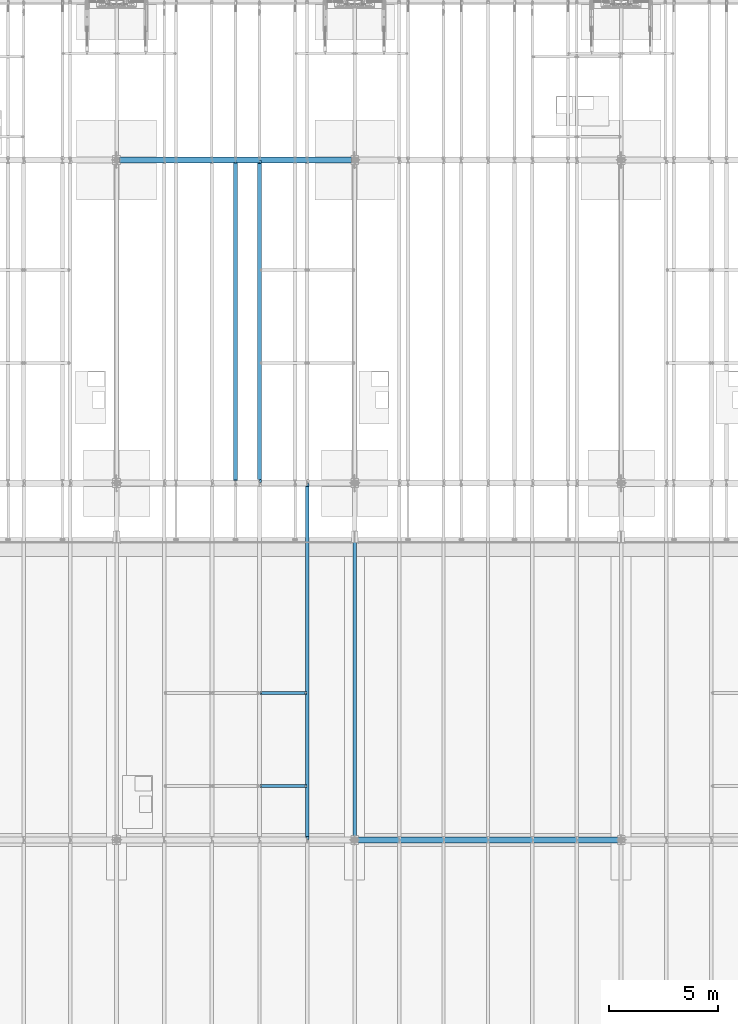
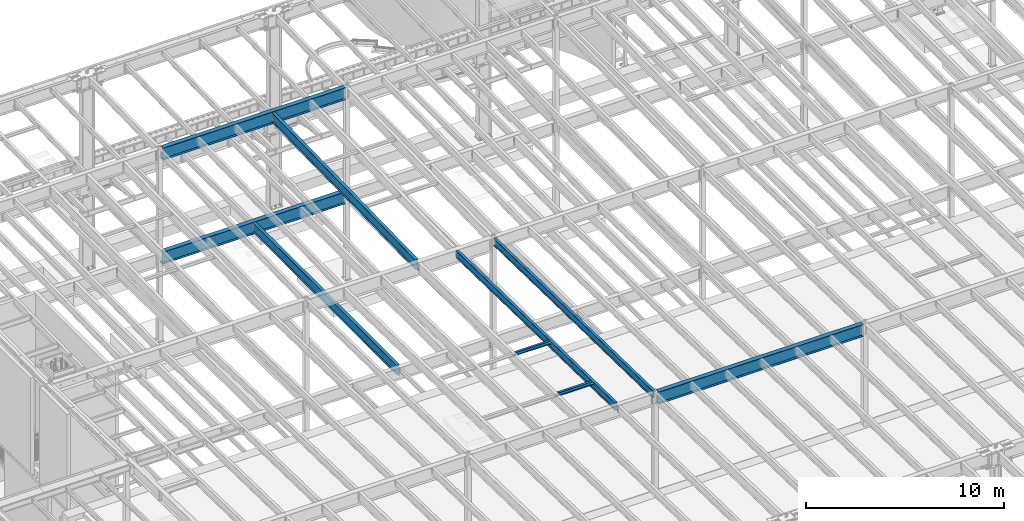
# One storey, part 1099 of 1763: 9 beams, 9 elements without a shape of their own.
"""IFC2X3 building model written with IfcOpenShell, lengths in millimetres."""

from ifc_helpers import new_model, si_unit, frame, origin_with_axes, place, context, subcontext, project, spatial, faceted_brep, material, type_object, element, aggregate, save


model = new_model("IFC2X3")

# Units and contexts
model_context = context("Model", 3, precision=1e-05, world=origin_with_axes())
body_context = subcontext(model_context, "Body", "Model", "MODEL_VIEW")
ifc_project = project(units=[si_unit("LENGTHUNIT", "METRE", prefix="MILLI"), si_unit("AREAUNIT", "SQUARE_METRE"), si_unit("VOLUMEUNIT", "CUBIC_METRE"), si_unit("MASSUNIT", "GRAM", prefix="KILO"), si_unit("TIMEUNIT", "SECOND"), si_unit("PLANEANGLEUNIT", "RADIAN"), si_unit("SOLIDANGLEUNIT", "STERADIAN"), si_unit("THERMODYNAMICTEMPERATUREUNIT", "DEGREE_CELSIUS"), si_unit("LUMINOUSINTENSITYUNIT", "LUMEN")], contexts=[model_context])

# Site, building, storey
site_placement = place(None, origin_with_axes())
site = spatial("IfcSite", under=ifc_project, at=site_placement, CompositionType="ELEMENT")
building_placement = place(site_placement, origin_with_axes())
building = spatial("IfcBuilding", under=site, at=building_placement, Name="Undefined", CompositionType="ELEMENT")
storey_placement = place(building_placement, origin_with_axes())
storey = spatial("IfcBuildingStorey", under=building, at=storey_placement, Name="Undefined", CompositionType="ELEMENT", Elevation=0.0)

# Assembly, beam
assembly_1_placement = place(storey_placement, origin_with_axes())
assembly_1 = element("IfcElementAssembly", 1, at=assembly_1_placement, inside=storey, Name="BEAM", AssemblyPlace="NOTDEFINED", PredefinedType="RIGID_FRAME")
ifc_material = material(Name="STEEL/A992")
beam_type_1 = type_object("IfcBeamType", Name="W8X18", PredefinedType="NOTDEFINED")
beam_1_placement = place(assembly_1_placement, frame((-65953.0772736984, 20421.6, 11387.8344547136), z_axis=(0.0, 0.0, 1.0), x_axis=(1.0, 0.0, 0.0)))
beam_1 = element("IfcBeam", 2, at=beam_1_placement, type_object=beam_type_1, material=ifc_material, Name="BEAM", ObjectType="W8X18", context=body_context, shape_type="Brep", body=[
    faceted_brep([(2086.45125000002, -66.6749999999993, 103.1875), (2086.45125000002, -66.6749999999993, 95.25), (2086.45125000002, -3.17499999999927, 95.25), (2086.45125000002, -3.17499999999927, 83.8775014899638), (2086.45125000002, 3.17499999999927, 83.8775014899638), (2086.45125000002, 3.17499999999927, 95.25), (2086.45125000002, 66.6749999999993, 95.25), (2086.45125000002, 66.6749999999993, 103.1875), (2087.41797992261, -3.17499999999927, 79.0174219719174), (2087.41797992261, 3.17499999999927, 79.0174219719174), (2090.17099382309, -3.17499999999927, 74.8972455037638), (2090.17099382309, 3.17499999999927, 74.8972455037638), (2094.29117029124, -3.17499999999927, 72.1442316032862), (2094.29117029124, 3.17499999999927, 72.1442316032862), (2099.15124980929, -3.17499999999927, 71.1775016806987), (2099.15124980929, 3.17499999999927, 71.1775016806987), (2162.65125000002, -3.17499999999927, 71.1775016806987), (2162.65125000002, 3.17499999999927, 71.1775016806987), (101.599996948244, -66.6750000000002, 103.1875), (101.599996948244, 66.6750000000002, 103.1875), (101.599996948244, 66.6750000000002, 95.25), (101.599996948244, 3.17500000000018, 95.25), (101.599996948244, 3.17500000000018, 79.3006453379949), (101.599996948244, -3.17500000000018, 79.3006453379949), (101.599996948244, -3.17500000000018, 95.25), (101.599996948244, -66.6750000000002, 95.25), (100.633267025656, 3.17500000000018, 74.4405658199485), (100.633267025656, -3.17500000000018, 74.4405658199485), (97.8802531251786, 3.17500000000018, 70.3203893517948), (97.8802531251786, -3.17500000000018, 70.3203893517948), (97.1527139098253, 3.17500000000018, 69.8342631898486), (97.1527139098253, -3.17500000000018, 69.8342631898486), (96.2927561769247, 3.17500000000018, 68.5472454911378), (96.2927561769247, -3.17500000000018, 68.5472454911378), (92.1725797087711, 3.17500000000018, 65.7942315906603), (92.1725797087711, -3.17500000000018, 65.7942315906603), (87.3125001907247, 3.17500000000018, 64.8275016680727), (87.3125001907247, -3.17500000000018, 64.8275016680727), (17.4624999999905, 3.17500000000018, 64.8275016680727), (17.4624999999905, -3.17500000000018, 64.8275016680727), (17.4624999999905, 3.17500000000018, -95.25), (17.4624999999905, 66.6750000000002, -95.25), (17.4624999999905, 66.6750000000002, -103.1875), (17.4624999999905, -66.6750000000002, -103.1875), (17.4624999999905, -66.6750000000002, -95.25), (17.4624999999905, -3.17500000000018, -95.25), (2162.65125000002, 3.17499999999927, -95.25), (2162.65125000002, 66.6749999999993, -95.25), (2162.65125000002, 66.6749999999993, -103.1875), (2162.65125000002, -66.6749999999993, -103.1875), (2162.65125000002, -66.6749999999993, -95.25), (2162.65125000002, -3.17499999999927, -95.25)], [[[0, 1, 2, 3, 4, 5, 6, 7]], [[8, 9, 4, 3]], [[10, 11, 9, 8]], [[12, 13, 11, 10]], [[14, 15, 13, 12]], [[16, 17, 15, 14]], [[18, 19, 20, 21, 22, 23, 24, 25]], [[23, 22, 26, 27]], [[27, 26, 28, 29]], [[29, 28, 30, 31]], [[31, 30, 32, 33]], [[33, 32, 34, 35]], [[35, 34, 36, 37]], [[37, 36, 38, 39]], [[40, 41, 42, 43, 44, 45, 39, 38]], [[41, 40, 46, 47]], [[42, 41, 47, 48]], [[43, 42, 48, 49]], [[44, 43, 49, 50]], [[45, 44, 50, 51]], [[12, 10, 8, 3, 2, 24, 23, 27, 29, 31, 33, 35, 37, 39, 45, 51, 16, 14]], [[25, 24, 2, 1]], [[18, 25, 1, 0]], [[19, 18, 0, 7]], [[20, 19, 7, 6]], [[21, 20, 6, 5]], [[46, 40, 38, 36, 34, 32, 30, 28, 26, 22, 21, 5, 4, 9, 11, 13, 15, 17]], [[51, 50, 49, 48, 47, 46, 17, 16]]]),
])
aggregate(assembly_1, [beam_1])

assembly_2_placement = place(storey_placement, origin_with_axes())
assembly_2 = element("IfcElementAssembly", 3, at=assembly_2_placement, inside=storey, Name="BEAM", AssemblyPlace="NOTDEFINED", PredefinedType="RIGID_FRAME")
beam_2_placement = place(assembly_2_placement, frame((-65953.0772736984, 16154.4, 11477.0442138004), z_axis=(0.0, 0.0, 1.0), x_axis=(1.0, 0.0, 0.0)))
beam_2 = element("IfcBeam", 4, at=beam_2_placement, type_object=beam_type_1, material=ifc_material, Name="BEAM", ObjectType="W8X18", context=body_context, shape_type="Brep", body=[
    faceted_brep([(2086.45125000002, -66.6749999999993, 103.1875), (2086.45125000002, -66.6749999999993, 95.25), (2086.45125000002, -3.17499999999927, 95.25), (2086.45125000002, -3.17499999999927, 83.8775014899638), (2086.45125000002, 3.17499999999927, 83.8775014899638), (2086.45125000002, 3.17499999999927, 95.25), (2086.45125000002, 66.6749999999993, 95.25), (2086.45125000002, 66.6749999999993, 103.1875), (2087.41797992261, -3.17499999999927, 79.0174219719174), (2087.41797992261, 3.17499999999927, 79.0174219719174), (2090.17099382309, -3.17499999999927, 74.8972455037638), (2090.17099382309, 3.17499999999927, 74.8972455037638), (2094.29117029124, -3.17499999999927, 72.1442316032862), (2094.29117029124, 3.17499999999927, 72.1442316032862), (2099.15124980929, -3.17499999999927, 71.1775016806987), (2099.15124980929, 3.17499999999927, 71.1775016806987), (2162.65125000002, -3.17499999999927, 71.1775016806987), (2162.65125000002, 3.17499999999927, 71.1775016806987), (101.599996948244, -66.6750000000002, 103.1875), (101.599996948244, 66.6750000000002, 103.1875), (101.599996948244, 66.6750000000002, 95.25), (101.599996948244, 3.17500000000018, 95.25), (101.599996948244, 3.17500000000018, 79.3006453379949), (101.599996948244, -3.17500000000018, 79.3006453379949), (101.599996948244, -3.17500000000018, 95.25), (101.599996948244, -66.6750000000002, 95.25), (100.633267025656, 3.17500000000018, 74.4405658199485), (100.633267025656, -3.17500000000018, 74.4405658199485), (97.8802531251786, 3.17500000000018, 70.3203893517948), (97.8802531251786, -3.17500000000018, 70.3203893517948), (97.1527139098253, 3.17500000000018, 69.8342631898486), (97.1527139098253, -3.17500000000018, 69.8342631898486), (96.2927561769247, 3.17500000000018, 68.5472454911378), (96.2927561769247, -3.17500000000018, 68.5472454911378), (92.1725797087711, 3.17500000000018, 65.7942315906603), (92.1725797087711, -3.17500000000018, 65.7942315906603), (87.3125001907247, 3.17500000000018, 64.8275016680727), (87.3125001907247, -3.17500000000018, 64.8275016680727), (17.4624999999905, 3.17500000000018, 64.8275016680727), (17.4624999999905, -3.17500000000018, 64.8275016680727), (17.4624999999905, 3.17500000000018, -95.25), (17.4624999999905, 66.6750000000002, -95.25), (17.4624999999905, 66.6750000000002, -103.1875), (17.4624999999905, -66.6750000000002, -103.1875), (17.4624999999905, -66.6750000000002, -95.25), (17.4624999999905, -3.17500000000018, -95.25), (2162.65125000002, 3.17499999999927, -95.25), (2162.65125000002, 66.6749999999993, -95.25), (2162.65125000002, 66.6749999999993, -103.1875), (2162.65125000002, -66.6749999999993, -103.1875), (2162.65125000002, -66.6749999999993, -95.25), (2162.65125000002, -3.17499999999927, -95.25)], [[[0, 1, 2, 3, 4, 5, 6, 7]], [[8, 9, 4, 3]], [[10, 11, 9, 8]], [[12, 13, 11, 10]], [[14, 15, 13, 12]], [[16, 17, 15, 14]], [[18, 19, 20, 21, 22, 23, 24, 25]], [[23, 22, 26, 27]], [[27, 26, 28, 29]], [[29, 28, 30, 31]], [[31, 30, 32, 33]], [[33, 32, 34, 35]], [[35, 34, 36, 37]], [[37, 36, 38, 39]], [[40, 41, 42, 43, 44, 45, 39, 38]], [[41, 40, 46, 47]], [[42, 41, 47, 48]], [[43, 42, 48, 49]], [[44, 43, 49, 50]], [[45, 44, 50, 51]], [[12, 10, 8, 3, 2, 24, 23, 27, 29, 31, 33, 35, 37, 39, 45, 51, 16, 14]], [[25, 24, 2, 1]], [[18, 25, 1, 0]], [[19, 18, 0, 7]], [[20, 19, 7, 6]], [[21, 20, 6, 5]], [[46, 40, 38, 36, 34, 32, 30, 28, 26, 22, 21, 5, 4, 9, 11, 13, 15, 17]], [[51, 50, 49, 48, 47, 46, 17, 16]]]),
])
aggregate(assembly_2, [beam_2])

assembly_3_placement = place(storey_placement, origin_with_axes())
assembly_3 = element("IfcElementAssembly", 5, at=assembly_3_placement, inside=storey, Name="BEAM", AssemblyPlace="NOTDEFINED", PredefinedType="RIGID_FRAME")
beam_type_2 = type_object("IfcBeamType", Name="W18X40", PredefinedType="NOTDEFINED")
beam_3_placement = place(assembly_3_placement, frame((-61594.4372736983, 13685.8551306911, 11404.7768219844), z_axis=(0.0, 0.0209013539966291, 0.999781542838788), x_axis=(0.0, 0.999781542776098, -0.0209013569953182)))
beam_3 = element("IfcBeam", 6, at=beam_3_placement, type_object=beam_type_2, material=ifc_material, Name="BEAM", ObjectType="W18X40", context=body_context, shape_type="Brep", body=[
    faceted_brep([(149.222337311263, -76.1999999999971, -227.012499999879), (149.222337311263, 76.1999999999971, -227.012499999879), (16200.7664130645, 76.1999999999971, -227.012499990429), (16200.7664130645, -76.1999999999971, -227.012499990429), (148.956832075886, -76.1999999999971, -214.31249999988), (148.956832075886, -3.96875, -214.31249999988), (139.996051629378, -3.96875, 214.31249999976), (139.996051629378, -76.1999999999971, 214.31249999976), (139.730529250521, -76.1999999999971, 227.012499999752), (139.730529250521, 76.1999999999971, 227.012499999752), (139.996051629378, 76.1999999999971, 214.31249999976), (139.996051629378, 3.96875, 214.31249999976), (148.956832075886, 3.96875, -214.31249999988), (148.956832075886, 76.1999999999971, -214.31249999988), (16200.5009078292, -76.1999999999971, -214.31249999043), (16200.5009078292, -3.96875, -214.31249999043), (16191.5401061352, -3.96875, 214.312500009502), (16191.5401061352, -76.1999999999971, 214.312500009502), (16191.2746008998, -76.1999999999971, 227.012500009499), (16191.2746008998, 76.1999999999971, 227.012500009499), (16191.5401061352, 76.1999999999971, 214.312500009502), (16191.5401061352, 3.96875, 214.312500009502), (16200.5009078292, 3.96875, -214.31249999043), (16200.5009078292, 76.1999999999971, -214.31249999043)], [[[0, 1, 2, 3]], [[0, 4, 5, 6, 7, 8, 9, 10, 11, 12, 13, 1]], [[5, 4, 14, 15]], [[6, 5, 15, 16]], [[7, 6, 16, 17]], [[8, 7, 17, 18]], [[9, 8, 18, 19]], [[10, 9, 19, 20]], [[11, 10, 20, 21]], [[12, 11, 21, 22]], [[13, 12, 22, 23]], [[1, 13, 23, 2]], [[22, 21, 20, 19, 18, 17, 16, 15, 14, 3, 2, 23]], [[4, 0, 3, 14]]]),
])
aggregate(assembly_3, [beam_3])

assembly_4_placement = place(storey_placement, origin_with_axes())
assembly_4 = element("IfcElementAssembly", 7, at=assembly_4_placement, inside=storey, Name="BEAM", AssemblyPlace="NOTDEFINED", PredefinedType="RIGID_FRAME")
beam_4_placement = place(assembly_4_placement, frame((-63773.7572736983, 13685.8551306872, 11404.7768219843), z_axis=(0.0, 0.0209013539966291, 0.999781542838788), x_axis=(0.0, 0.999781542776098, -0.0209013569953182)))
beam_4 = element("IfcBeam", 8, at=beam_4_placement, type_object=beam_type_2, material=ifc_material, Name="BEAM", ObjectType="W18X40", context=body_context, shape_type="Brep", body=[
    faceted_brep([(131.750078376836, 4.26866853544198, -214.312499999891), (131.750078376825, 4.26882839153404, -227.012499999888), (28.545974688046, 4.26881528460945, -227.012499999948), (28.2804694526694, 4.26865539480787, -214.312499999951), (131.750069241622, 76.1999999999971, -214.312499999891), (131.750069241631, 76.1999999999971, -227.012499999888), (150.800068605527, -3.96875, 195.002501487816), (150.800068605527, 3.96875, 195.002501487816), (149.833338682944, 3.96875, 190.142421969771), (149.833338682944, -3.96875, 190.142421969771), (147.080324782468, 3.96875, 186.022245501617), (147.080324782468, -3.96875, 186.022245501617), (142.96014831432, 3.96875, 183.26923160114), (142.96014831432, -3.96875, 183.26923160114), (138.100068796275, 3.96875, 182.30250167855), (138.100068796275, -3.96875, 182.30250167855), (19.9888663522943, 3.96875, 182.30250167848), (19.9888663522943, -3.96875, 182.30250167848), (28.2804694526694, -3.96875, -214.312499999951), (16325.1468877506, -3.96875, -214.312499990354), (16316.8552846474, -3.96875, 182.302501822591), (16187.3164867041, -3.96875, 182.302501822514), (16182.456407186, -3.96875, 183.269231745098), (16178.3362307179, -3.96875, 186.022245645572), (16175.5832168174, -3.96875, 190.142422113722), (16174.6164868948, -3.96875, 195.002501631765), (16174.6164868948, -3.96875, 214.312500009495), (150.800068605517, -3.96875, 214.312500000058), (28.2804694526694, -76.1999999999971, -214.312499999951), (16325.1468877506, -76.1999999999971, -214.312499990354), (28.545974688046, -76.1999999999971, -227.012499999948), (16325.412392986, -76.1999999999971, -227.012499990351), (16219.0664848027, 4.26882844082138, -214.312499990418), (16219.0664848027, 4.26866859193979, -227.012499990415), (16219.0664786887, 76.1999999999971, -227.012499990416), (16219.0664786887, 76.1999999999971, -214.312499990416), (16325.412392986, 4.2686776052069, -227.012499990351), (16325.1468877506, 4.26883743175858, -214.312499990354), (16325.1468877506, 3.96875, -214.312499990354), (16316.8552846474, 3.96875, 182.302501822591), (16187.3164867041, 3.96875, 182.302501822514), (16182.456407186, 3.96875, 183.269231745098), (16178.3362307179, 3.96875, 186.022245645572), (16175.5832168174, 3.96875, 190.142422113722), (16174.6164868948, 3.96875, 195.002501631765), (16174.6164868948, -76.1999999999971, 227.01250000949), (16174.6164868948, -76.1999999999971, 214.312500009495), (16174.6164868948, 3.96875, 214.312500009495), (16174.6164868948, 76.1999999999971, 214.312500009495), (16174.6164868948, 76.1999999999971, 227.01250000949), (150.800068605517, 3.96875, 214.312500000058), (150.800068605517, 76.1999999999971, 214.312500000058), (150.800068605509, 76.1999999999971, 227.012500000057), (150.800068605509, -76.1999999999971, 227.012500000057), (150.800068605517, -76.1999999999971, 214.312500000058), (28.2804694526694, 3.96875, -214.312499999951)], [[[0, 1, 2, 3]], [[4, 5, 1, 0]], [[6, 7, 8, 9]], [[9, 8, 10, 11]], [[11, 10, 12, 13]], [[13, 12, 14, 15]], [[15, 14, 16, 17]], [[9, 11, 13, 15, 17, 18, 19, 20, 21, 22, 23, 24, 25, 26, 27, 6]], [[18, 28, 29, 19]], [[28, 30, 31, 29]], [[32, 33, 34, 35]], [[36, 33, 32, 37]], [[38, 39, 20, 19, 29, 31, 36, 37]], [[20, 39, 40, 21]], [[21, 40, 41, 22]], [[22, 41, 42, 23]], [[23, 42, 43, 24]], [[24, 43, 44, 25]], [[45, 46, 26, 25, 44, 47, 48, 49]], [[48, 47, 50, 51]], [[49, 48, 51, 52]], [[45, 49, 52, 53]], [[46, 45, 53, 54]], [[26, 46, 54, 27]], [[53, 52, 51, 50, 7, 6, 27, 54]], [[47, 44, 43, 42, 41, 40, 39, 38, 55, 16, 14, 12, 10, 8, 7, 50]], [[30, 28, 18, 17, 16, 55, 3, 2]], [[34, 33, 36, 31, 30, 2, 1, 5]], [[35, 34, 5, 4]], [[55, 38, 37, 32, 35, 4, 0, 3]]]),
])
aggregate(assembly_4, [beam_4])

assembly_5_placement = place(storey_placement, origin_with_axes())
assembly_5 = element("IfcElementAssembly", 9, at=assembly_5_placement, inside=storey, Name="BEAM", AssemblyPlace="NOTDEFINED", PredefinedType="RIGID_FRAME")
beam_type_3 = type_object("IfcBeamType", Name="W24X55", PredefinedType="NOTDEFINED")
beam_5_placement = place(assembly_5_placement, frame((-65953.0772736983, 30029.0063442244, 10990.3266966851), z_axis=(0.0, -0.0206852279954837, 0.999786037781472), x_axis=(0.0, 0.999786037781472, 0.0206852279954825)))
beam_5 = element("IfcBeam", 10, at=beam_5_placement, type_object=beam_type_3, material=ifc_material, Name="BEAM", ObjectType="W24X55", context=body_context, shape_type="Brep", body=[
    faceted_brep([(146.990330008142, 5.06237880179833, -287.33749999981), (146.990330008142, 5.06261812571756, -300.0374999998), (7.43265181667448, 5.06260883843788, -300.037499999775), (7.69541043263234, 5.06236953187909, -287.337499999783), (146.990324474755, 88.9000000000015, -287.33749999981), (146.990324474751, 88.9000000000015, -300.0374999998), (159.690324117899, -4.76249999999709, 261.677501487318), (159.690324117899, 4.76249999999709, 261.677501487318), (158.723594195311, 4.76249999999709, 256.817421969285), (158.723594195311, -4.76249999999709, 256.817421969285), (155.970580294834, 4.76249999999709, 252.697245501142), (155.970580294834, -4.76249999999709, 252.697245501142), (151.850403826695, 4.76249999999709, 249.944231600668), (151.850403826695, -4.76249999999709, 249.944231600668), (146.990324308659, 4.76249999999709, 248.977501678084), (146.990324308659, -4.76249999999709, 248.977501678084), (18.7915826813696, 4.76249999999709, 248.97750167811), (18.7915826813696, -4.76249999999709, 248.97750167811), (7.69541043263234, -4.76249999999709, -287.337499999783), (14754.7569745369, -4.76249999999709, -287.337500002592), (14765.8531467848, -4.76249999999709, 248.977501635871), (14640.0518880073, -4.76249999999709, 248.977501635894), (14635.1918084892, -4.76249999999709, 249.944231558482), (14631.0716320211, -4.76249999999709, 252.697245458956), (14628.3186181206, -4.76249999999709, 256.817421927099), (14627.351888198, -4.76249999999709, 261.677501445134), (14627.351888198, -4.76249999999709, 287.337499997), (159.690324117902, -4.76249999999709, 287.337499999756), (7.69541043263234, -88.9000000000015, -287.337499999783), (14754.7569745369, -88.9000000000015, -287.337500002592), (7.43265181667448, -88.9000000000015, -300.037499999775), (14754.4942159209, -88.9000000000015, -300.037500002583), (14640.051883239, 5.06261810508295, -287.33750000257), (14640.051883239, 5.06237878320098, -300.03750000256), (14640.0518719211, 88.9000000000015, -300.037500002562), (14640.0518719211, 88.9000000000015, -287.337500002572), (14754.7569745369, 5.0626335900306, -287.337500002592), (14754.4942159209, 5.06239423266379, -300.037500002583), (14754.7569745369, 4.76249999999709, -287.337500002592), (14765.8531467848, 4.76249999999709, 248.977501635871), (14640.0518880073, 4.76249999999709, 248.977501635894), (14635.1918084892, 4.76249999999709, 249.944231558482), (14631.0716320211, 4.76249999999709, 252.697245458956), (14628.3186181206, 4.76249999999709, 256.817421927099), (14627.351888198, 4.76249999999709, 261.677501445134), (14627.351888198, -88.9000000000015, 300.03749999699), (14627.351888198, -88.9000000000015, 287.337499997), (14627.351888198, 4.76249999999709, 287.337499997), (14627.351888198, 88.9000000000015, 287.337499997), (14627.351888198, 88.9000000000015, 300.03749999699), (159.690324117902, 4.76249999999709, 287.337499999756), (159.690324117902, 88.9000000000015, 287.337499999756), (159.690324117906, 88.9000000000015, 300.037499999746), (159.690324117906, -88.9000000000015, 300.037499999746), (159.690324117902, -88.9000000000015, 287.337499999756), (7.69541043263234, 4.76249999999709, -287.337499999783)], [[[0, 1, 2, 3]], [[4, 5, 1, 0]], [[6, 7, 8, 9]], [[9, 8, 10, 11]], [[11, 10, 12, 13]], [[13, 12, 14, 15]], [[15, 14, 16, 17]], [[9, 11, 13, 15, 17, 18, 19, 20, 21, 22, 23, 24, 25, 26, 27, 6]], [[18, 28, 29, 19]], [[28, 30, 31, 29]], [[32, 33, 34, 35]], [[36, 37, 33, 32]], [[38, 39, 20, 19, 29, 31, 37, 36]], [[20, 39, 40, 21]], [[21, 40, 41, 22]], [[22, 41, 42, 23]], [[23, 42, 43, 24]], [[24, 43, 44, 25]], [[45, 46, 26, 25, 44, 47, 48, 49]], [[48, 47, 50, 51]], [[49, 48, 51, 52]], [[45, 49, 52, 53]], [[46, 45, 53, 54]], [[26, 46, 54, 27]], [[53, 52, 51, 50, 7, 6, 27, 54]], [[47, 44, 43, 42, 41, 40, 39, 38, 55, 16, 14, 12, 10, 8, 7, 50]], [[30, 28, 18, 17, 16, 55, 3, 2]], [[34, 33, 37, 31, 30, 2, 1, 5]], [[35, 34, 5, 4]], [[55, 38, 36, 32, 35, 4, 0, 3]]]),
])
aggregate(assembly_5, [beam_5])

assembly_6_placement = place(storey_placement, origin_with_axes())
assembly_6 = element("IfcElementAssembly", 11, at=assembly_6_placement, inside=storey, Name="BEAM", AssemblyPlace="NOTDEFINED", PredefinedType="RIGID_FRAME")
beam_6_placement = place(assembly_6_placement, frame((-67042.7372736984, 30022.8, 4894.2625), z_axis=(0.0, 0.0, 1.0), x_axis=(0.0, 1.0, 0.0)))
beam_6 = element("IfcBeam", 12, at=beam_6_placement, type_object=beam_type_3, material=ifc_material, Name="BEAM", ObjectType="W24X55", context=body_context, shape_type="Brep", body=[
    faceted_brep([(19.0499999999993, -5.06263026501983, -287.3375), (19.0499999999993, -5.06239088271832, -300.0375), (120.650010238503, -5.06237879249238, -300.0375), (120.650010238547, -5.06261817480845, -287.3375), (120.650020215031, -88.9000000000015, -287.3375), (120.650020215031, -88.9000000000015, -300.0375), (146.049999999999, -4.76249999999709, 280.727501487732), (146.049999999999, 4.76249999999709, 280.727501487732), (145.083270077412, 4.76249999999709, 275.867421969687), (145.083270077412, -4.76249999999709, 275.867421969687), (142.330256176934, 4.76249999999709, 271.747245501533), (142.330256176934, -4.76249999999709, 271.747245501533), (138.210079708781, 4.76249999999709, 268.994231601055), (138.210079708781, -4.76249999999709, 268.994231601055), (133.350000190734, 4.76249999999709, 268.027501678467), (133.350000190734, -4.76249999999709, 268.027501678467), (19.0499999999993, 4.76249999999709, 268.027501678467), (19.0499999999993, -4.76249999999709, 268.027501678467), (19.0499999999993, -4.76249999999709, -287.3375), (14763.75, -4.76249999999709, -287.3375), (14763.75, -4.76249999999709, 268.027501678466), (14649.4499998093, -4.76249999999709, 268.027501678466), (14644.5899202912, -4.76249999999709, 268.994231601054), (14640.4697438231, -4.76249999999709, 271.747245501532), (14637.7167299226, -4.76249999999709, 275.867421969686), (14636.75, -4.76249999999709, 280.727501487731), (14636.75, -4.76249999999709, 287.3375), (146.049999999999, -4.76249999999709, 287.3375), (14763.75, 4.76249999999709, 268.027501678466), (14649.4499998093, 4.76249999999709, 268.027501678466), (14644.5899202912, 4.76249999999709, 268.994231601054), (14640.4697438231, 4.76249999999709, 271.747245501532), (14637.7167299226, 4.76249999999709, 275.867421969686), (14636.75, 4.76249999999709, 280.727501487731), (14636.75, -88.9000000000015, 300.0375), (14636.75, -88.9000000000015, 287.3375), (14636.75, 4.76249999999709, 287.3375), (14636.75, 88.9000000000015, 287.3375), (14636.75, 88.9000000000015, 300.0375), (146.049999999999, 4.76249999999709, 287.3375), (146.049999999999, 88.9000000000015, 287.3375), (146.049999999999, 88.9000000000015, 300.0375), (146.049999999999, -88.9000000000015, 300.0375), (146.049999999999, -88.9000000000015, 287.3375), (14763.75, 4.76249999999709, -287.3375), (19.0499999999993, 4.76249999999709, -287.3375), (14763.75, 5.06263026504894, -287.3375), (14662.1499897615, 5.06261817483755, -287.3375), (14662.1499797849, 88.9000000000015, -287.3375), (120.650000595357, 88.9000000000015, -287.3375), (120.650010572102, 5.06237876442901, -287.3375), (19.0499999999993, 5.06236667421763, -287.3375), (120.650010572055, 5.06261814674508, -300.0375), (19.0499999999993, 5.06260605652642, -300.0375), (120.650000595357, 88.9000000000015, -300.0375), (14662.1499797849, 88.9000000000015, -300.0375), (14662.1499897615, 5.06237879252149, -300.0375), (14763.75, 5.06239088274742, -300.0375), (14763.75, -5.06236667417397, -287.3375), (14763.75, -5.06260605648276, -300.0375), (14662.1499894279, -5.06237876438536, -287.3375), (14662.1499894279, -5.06261814670142, -300.0375), (14662.1499994046, -88.9000000000015, -287.3375), (14662.1499994046, -88.9000000000015, -300.0375)], [[[0, 1, 2, 3]], [[4, 3, 2, 5]], [[6, 7, 8, 9]], [[9, 8, 10, 11]], [[11, 10, 12, 13]], [[13, 12, 14, 15]], [[15, 14, 16, 17]], [[9, 11, 13, 15, 17, 18, 19, 20, 21, 22, 23, 24, 25, 26, 27, 6]], [[20, 28, 29, 21]], [[21, 29, 30, 22]], [[22, 30, 31, 23]], [[23, 31, 32, 24]], [[24, 32, 33, 25]], [[34, 35, 26, 25, 33, 36, 37, 38]], [[37, 36, 39, 40]], [[38, 37, 40, 41]], [[34, 38, 41, 42]], [[35, 34, 42, 43]], [[26, 35, 43, 27]], [[42, 41, 40, 39, 7, 6, 27, 43]], [[36, 33, 32, 31, 30, 29, 28, 44, 45, 16, 14, 12, 10, 8, 7, 39]], [[45, 44, 46, 47, 48, 49, 50, 51]], [[50, 52, 53, 51]], [[49, 54, 52, 50]], [[48, 55, 54, 49]], [[47, 56, 55, 48]], [[46, 57, 56, 47]], [[44, 28, 20, 19, 58, 59, 57, 46]], [[58, 60, 61, 59]], [[62, 63, 61, 60]], [[63, 62, 4, 5]], [[1, 53, 52, 54, 55, 56, 57, 59, 61, 63, 5, 2]], [[18, 17, 16, 45, 51, 53, 1, 0]], [[62, 60, 58, 19, 18, 0, 3, 4]]]),
])
aggregate(assembly_6, [beam_6])

assembly_7_placement = place(storey_placement, origin_with_axes())
assembly_7 = element("IfcElementAssembly", 13, at=assembly_7_placement, inside=storey, Name="BEAM", AssemblyPlace="NOTDEFINED", PredefinedType="RIGID_FRAME")
beam_type_4 = type_object("IfcBeamType", Name="W30X90", PredefinedType="NOTDEFINED")
beam_7_placement = place(assembly_7_placement, frame((-61594.4372736983, 13690.599999996, 11257.0897294638), z_axis=(0.0, 0.0, 1.0), x_axis=(1.0, 0.0, 0.0)))
beam_7 = element("IfcBeam", 14, at=beam_7_placement, type_object=beam_type_4, material=ifc_material, Name="BEAM", ObjectType="W30X90", context=body_context, shape_type="Brep", body=[
    faceted_brep([(139.699999999997, 131.762500000001, -374.65), (139.699999999997, 131.762500000001, -358.775), (12052.3, 131.762500000001, -358.775), (12052.3, 131.762500000001, -374.65), (139.699999999997, 6.35000000000036, -358.775), (12052.3, 6.35000000000036, -358.775), (139.699999999997, 6.35000000000036, 358.775), (12052.3, 6.35000000000036, 358.775), (139.699999999997, 131.762500000001, 358.775), (12052.3, 131.762500000001, 358.775), (139.699999999997, 131.762500000001, 374.65), (12052.3, 131.762500000001, 374.65), (139.699999999997, -131.762500000001, 374.65), (12052.3, -131.762500000001, 374.65), (139.699999999997, -131.762500000001, 358.775), (12052.3, -131.762500000001, 358.775), (139.699999999997, -6.35000000000036, 358.775), (12052.3, -6.35000000000036, 358.775), (139.699999999997, -6.35000000000036, -358.775), (12052.3, -6.35000000000036, -358.775), (139.699999999997, -131.762500000001, -358.775), (12052.3, -131.762500000001, -358.775), (139.699999999997, -131.762500000001, -374.65), (12052.3, -131.762500000001, -374.65)], [[[0, 1, 2, 3]], [[1, 4, 5, 2]], [[4, 6, 7, 5]], [[6, 8, 9, 7]], [[8, 10, 11, 9]], [[10, 12, 13, 11]], [[12, 14, 15, 13]], [[14, 16, 17, 15]], [[16, 18, 19, 17]], [[18, 20, 21, 19]], [[20, 22, 23, 21]], [[22, 0, 3, 23]], [[5, 7, 9, 11, 13, 15, 17, 19, 21, 23, 3, 2]], [[22, 20, 18, 16, 14, 12, 10, 8, 6, 4, 1, 0]]]),
])
aggregate(assembly_7, [beam_7])

assembly_8_placement = place(storey_placement, origin_with_axes())
assembly_8 = element("IfcElementAssembly", 15, at=assembly_8_placement, inside=storey, Name="BEAM", AssemblyPlace="NOTDEFINED", PredefinedType="RIGID_FRAME")
beam_8_placement = place(assembly_8_placement, frame((-72491.0372736984, 44805.5999999732, 11220.5088409688), z_axis=(0.0, 0.0, 1.0), x_axis=(1.0, 0.0, 0.0)))
beam_8 = element("IfcBeam", 16, at=beam_8_placement, type_object=beam_type_4, material=ifc_material, Name="BEAM", ObjectType="W30X90", context=body_context, shape_type="Brep", body=[
    faceted_brep([(141.287500000006, 131.762500000001, -374.65), (141.287500000006, 131.762500000001, -358.775), (10755.3125, 131.762499999997, -358.775), (10755.3125, 131.762499999997, -374.65), (141.287500000006, 6.34999999999854, -358.775), (10755.3125, 6.34999999999854, -358.775), (141.287500000006, 6.34999999999854, 358.775), (10755.3125, 6.34999999999854, 358.775), (141.287500000006, 131.762500000001, 358.775), (10755.3125, 131.762499999997, 358.775), (141.287500000006, 131.762500000001, 374.65), (10755.3125, 131.762499999997, 374.65), (141.287500000006, -131.762500000001, 374.65), (10755.3125, -131.762499999997, 374.65), (141.287500000006, -131.762500000001, 358.775), (10755.3125, -131.762499999997, 358.775), (141.287500000006, -6.34999999999854, 358.775), (10755.3125, -6.34999999999854, 358.775), (141.287500000006, -6.34999999999854, -358.775), (10755.3125, -6.34999999999854, -358.775), (141.287500000006, -131.762500000001, -358.775), (10755.3125, -131.762499999997, -358.775), (141.287500000006, -131.762500000001, -374.65), (10755.3125, -131.762499999997, -374.65)], [[[0, 1, 2, 3]], [[1, 4, 5, 2]], [[4, 6, 7, 5]], [[6, 8, 9, 7]], [[8, 10, 11, 9]], [[10, 12, 13, 11]], [[12, 14, 15, 13]], [[14, 16, 17, 15]], [[16, 18, 19, 17]], [[18, 20, 21, 19]], [[20, 22, 23, 21]], [[22, 0, 3, 23]], [[5, 7, 9, 11, 13, 15, 17, 19, 21, 23, 3, 2]], [[22, 20, 18, 16, 14, 12, 10, 8, 6, 4, 1, 0]]]),
])
aggregate(assembly_8, [beam_8])

assembly_9_placement = place(storey_placement, origin_with_axes())
assembly_9 = element("IfcElementAssembly", 17, at=assembly_9_placement, inside=storey, Name="BEAM", AssemblyPlace="NOTDEFINED", PredefinedType="RIGID_FRAME")
beam_9_placement = place(assembly_9_placement, frame((-72491.0372736984, 44805.6, 4819.65), z_axis=(0.0, 0.0, 1.0), x_axis=(1.0, 0.0, 0.0)))
beam_9 = element("IfcBeam", 18, at=beam_9_placement, type_object=beam_type_4, material=ifc_material, Name="BEAM", ObjectType="W30X90", context=body_context, shape_type="Brep", body=[
    faceted_brep([(141.287500000006, 131.762500000001, -374.65), (141.287500000006, 131.762500000001, -358.775), (10755.3125, 131.762499999997, -358.775), (10755.3125, 131.762499999997, -374.65), (141.287500000006, 6.34999999999854, -358.775), (10755.3125, 6.34999999999854, -358.775), (141.287500000006, 6.34999999999854, 358.775), (10755.3125, 6.34999999999854, 358.775), (141.287500000006, 131.762500000001, 358.775), (10755.3125, 131.762499999997, 358.775), (141.287500000006, 131.762500000001, 374.65), (10755.3125, 131.762499999997, 374.65), (141.287500000006, -131.762500000001, 374.65), (10755.3125, -131.762499999997, 374.65), (141.287500000006, -131.762500000001, 358.775), (10755.3125, -131.762499999997, 358.775), (141.287500000006, -6.34999999999854, 358.775), (10755.3125, -6.34999999999854, 358.775), (141.287500000006, -6.34999999999854, -358.775), (10755.3125, -6.34999999999854, -358.775), (141.287500000006, -131.762500000001, -358.775), (10755.3125, -131.762499999997, -358.775), (141.287500000006, -131.762500000001, -374.65), (10755.3125, -131.762499999997, -374.65)], [[[0, 1, 2, 3]], [[1, 4, 5, 2]], [[4, 6, 7, 5]], [[6, 8, 9, 7]], [[8, 10, 11, 9]], [[10, 12, 13, 11]], [[12, 14, 15, 13]], [[14, 16, 17, 15]], [[16, 18, 19, 17]], [[18, 20, 21, 19]], [[20, 22, 23, 21]], [[22, 0, 3, 23]], [[5, 7, 9, 11, 13, 15, 17, 19, 21, 23, 3, 2]], [[22, 20, 18, 16, 14, 12, 10, 8, 6, 4, 1, 0]]]),
])
aggregate(assembly_9, [beam_9])

save(model, "model.ifc")
